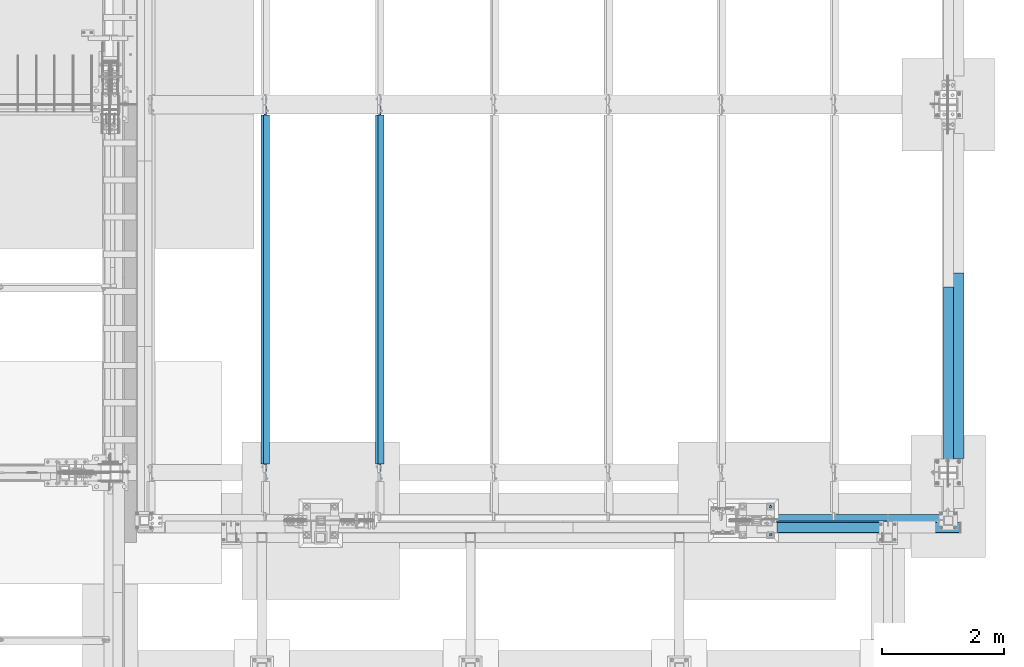
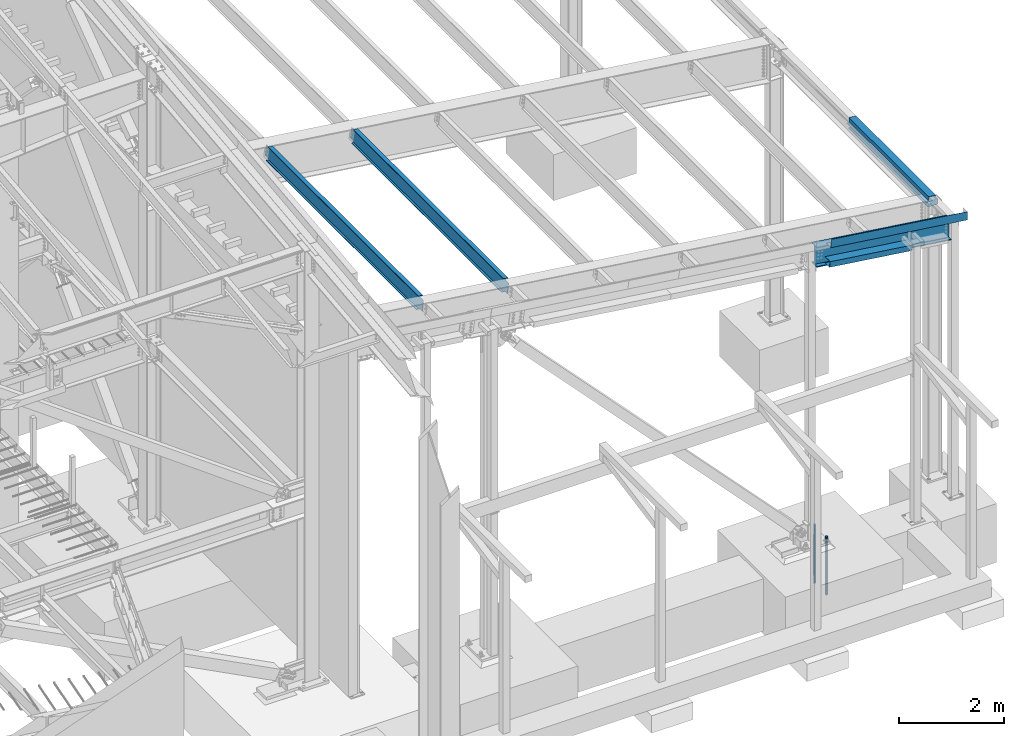
# One storey, part 746 of 1179: 9 beams, 5 elements without a shape of their own.
"""IFC2X3 building model written with IfcOpenShell, lengths in millimetres."""

from ifc_helpers import new_model, si_unit, frame, origin_with_axes, place, context, subcontext, project, spatial, faceted_brep, material, type_object, element, aggregate, save


model = new_model("IFC2X3")

# Units and contexts
model_context = context("Model", 3, precision=1e-05, world=origin_with_axes())
body_context = subcontext(model_context, "Body", "Model", "MODEL_VIEW")
ifc_project = project(units=[si_unit("LENGTHUNIT", "METRE", prefix="MILLI"), si_unit("AREAUNIT", "SQUARE_METRE"), si_unit("VOLUMEUNIT", "CUBIC_METRE"), si_unit("MASSUNIT", "GRAM", prefix="KILO"), si_unit("TIMEUNIT", "SECOND"), si_unit("PLANEANGLEUNIT", "RADIAN"), si_unit("SOLIDANGLEUNIT", "STERADIAN"), si_unit("THERMODYNAMICTEMPERATUREUNIT", "DEGREE_CELSIUS"), si_unit("LUMINOUSINTENSITYUNIT", "LUMEN")], contexts=[model_context])

# Site, building, storey
site_placement = place(None, origin_with_axes())
site = spatial("IfcSite", under=ifc_project, at=site_placement, CompositionType="ELEMENT")
building_placement = place(site_placement, origin_with_axes())
building = spatial("IfcBuilding", under=site, at=building_placement, Name="Undefined", CompositionType="ELEMENT")
storey_placement = place(building_placement, origin_with_axes())
storey = spatial("IfcBuildingStorey", under=building, at=storey_placement, Name="Undefined", CompositionType="ELEMENT", Elevation=0.0)

# Assembly, beams
assembly_1_placement = place(storey_placement, origin_with_axes())
assembly_1 = element("IfcElementAssembly", 1, at=assembly_1_placement, inside=storey, Name="BEAM", AssemblyPlace="NOTDEFINED", PredefinedType="RIGID_FRAME")
ifc_material_1 = material(Name="STEEL/A36")
beam_type_1 = type_object("IfcBeamType", PredefinedType="NOTDEFINED")
beam_1_placement = place(assembly_1_placement, frame((37996.8124994167, 6962.77499999974, 6096.00000000004), z_axis=(0.0, -1.0, 0.0), x_axis=(0.0, 0.0, 1.0)))
beam_1 = element("IfcBeam", 2, at=beam_1_placement, type_object=beam_type_1, material=ifc_material_1, Name="BENT_PLATE", context=body_context, shape_type="Brep", body=[
    faceted_brep([(-2.91038304567337e-11, -4.76250000000073, -1524.0), (-2.91038304567337e-11, -4.76250000000073, 1524.0), (2.91038304567337e-11, 4.76250000000073, 1524.0), (2.91038304567337e-11, 4.76250000000073, -1524.0), (92.8848876952779, 4.76250000074651, 1524.0), (92.8848876952779, 4.76250000074651, -1524.0), (81.9873102930469, -4.76249999933498, -1524.0), (81.9873102930469, -4.76249999933498, 1524.0), (70.5918350219381, -160.337506103519, 1524.0), (70.5918350219381, -160.337506103519, -1524.0), (62.266532833075, -150.812506103524, -1524.0), (62.266532833075, -150.812506103524, 1524.0), (-7.6397554948926e-11, -160.337506103519, 1524.0), (-7.6397554948926e-11, -160.337506103519, -1524.0), (8.54161044117063e-08, -150.812499999749, 1524.0), (8.54161044117063e-08, -150.812499999749, -1524.0)], [[[0, 1, 2, 3]], [[3, 2, 4, 5]], [[1, 0, 6, 7]], [[5, 4, 8, 9]], [[7, 6, 10, 11]], [[9, 8, 12, 13]], [[8, 4, 2, 1, 7, 11, 14, 12]], [[11, 10, 15, 14]], [[10, 6, 0, 3, 5, 9, 13, 15]], [[14, 15, 13, 12]]]),
])
beam_type_2 = type_object("IfcBeamType", PredefinedType="NOTDEFINED")
beam_2_placement = place(assembly_1_placement, frame((38112.7, 7189.78750000015, 5765.8), z_axis=(0.0, 1.0, 0.0), x_axis=(1.0, 0.0, 0.0)))
beam_2 = element("IfcBeam", 3, at=beam_2_placement, type_object=beam_type_2, material=ifc_material_1, Name="BENT_PLATE", context=body_context, shape_type="Brep", body=[
    faceted_brep([(0.0, -3.17499999999927, -1524.0), (6.00266503170133e-10, -3.17499999922438, 1524.00000000052), (6.00266503170133e-10, 3.17500000077416, 1524.00000000052), (0.0, 3.17499999999927, -1524.0), (215.900000000009, 3.17500000000018, 1524.0), (215.900000000009, 3.17500000000018, -1524.0), (209.550000000003, -3.17500000000018, -1524.0), (209.550000000003, -3.17500000000018, 1524.0), (215.900000000009, -123.825, 1524.0), (215.900000000009, -123.825, -1524.0), (209.550000000003, -117.474999999999, -1524.0), (209.550000000003, -117.474999999999, 1524.0), (-34.1312499999985, -123.825, 1524.0), (-34.1312499999985, -123.825, -1524.0), (-34.1312499999985, -117.474999999999, 1524.0), (-34.1312499999985, -117.474999999999, -1524.0)], [[[0, 1, 2, 3]], [[3, 2, 4, 5]], [[1, 0, 6, 7]], [[5, 4, 8, 9]], [[7, 6, 10, 11]], [[9, 8, 12, 13]], [[8, 4, 2, 1, 7, 11, 14, 12]], [[11, 10, 15, 14]], [[10, 6, 0, 3, 5, 9, 13, 15]], [[14, 15, 13, 12]]]),
])
aggregate(assembly_1, [beam_2, beam_1])

assembly_2_placement = place(storey_placement, origin_with_axes())
assembly_2 = element("IfcElementAssembly", 4, at=assembly_2_placement, inside=storey, Name="BEAM", AssemblyPlace="NOTDEFINED", PredefinedType="RIGID_FRAME")
beam_type_3 = type_object("IfcBeamType", PredefinedType="NOTDEFINED")
beam_3_placement = place(assembly_2_placement, frame((36794.3086923332, 4448.17500003039, 6542.84180397988), z_axis=(0.99100656965293, 0.0, -0.133813223953134), x_axis=(-0.133813222971046, 0.0, -0.991006569785539)))
beam_3 = element("IfcBeam", 5, at=beam_3_placement, type_object=beam_type_3, material=ifc_material_1, Name="BENT_PLATE", context=body_context, shape_type="Brep", body=[
    faceted_brep([(190.499999993961, -3.17500000000018, -1524.00000000063), (0.0, -3.17499999999927, -1524.0), (0.0, 3.17499999999927, -1524.0), (184.149999993959, 3.17500000000018, -1524.00000000062), (184.149999994715, 166.687499981327, -1524.00000000071), (190.499999994716, 166.687499981327, -1524.00000000072), (190.499999997646, -3.17500000000018, 1522.67681470571), (1.05865183286369e-09, -3.17500000000018, 1496.95405973812), (1.05865183286369e-09, 3.17500000000018, 1496.95405973813), (184.149999997644, 3.17500000000018, 1521.8193895401), (184.149999996893, 166.687499982885, 1521.81938954), (190.499999996895, 166.687499982886, 1522.67681470561)], [[[0, 1, 2, 3, 4, 5]], [[1, 0, 6, 7]], [[2, 1, 7, 8]], [[3, 2, 8, 9]], [[4, 3, 9, 10]], [[5, 4, 10, 11]], [[0, 5, 11, 6]], [[10, 9, 8, 7, 6, 11]]]),
])
beam_type_4 = type_object("IfcBeamType", PredefinedType="NOTDEFINED")
beam_4_placement = place(assembly_2_placement, frame((36156.5099994296, 4642.64374999811, 6109.94447129983), z_axis=(-0.99100656978554, 0.0, 0.133813222971043), x_axis=(0.0, -1.0, 0.0)))
beam_4 = element("IfcBeam", 6, at=beam_4_placement, type_object=beam_type_4, material=ifc_material_1, Name="BENT_PLATE", context=body_context, shape_type="Brep", body=[
    faceted_brep([(-2.72848410531878e-11, -3.17500000025393, -914.400000000191), (-2.72848410531878e-11, -3.17499999974825, 914.400000000205), (2.72848410531878e-11, 3.17500000025393, 914.400000000191), (2.72848410531878e-11, 3.17499999974825, -914.400000000198), (197.643750000188, 3.17499999857864, 914.400000000198), (197.643750000961, 3.1749999980766, -914.400000000205), (191.293750000961, -3.17500000187283, -914.400000000191), (191.293750000189, -3.17500000137079, 914.400000000198), (197.643750000575, -123.825000005945, 914.400000000394), (197.643750000575, -123.825000007779, -914.400000000001), (191.293750000575, -117.475000009899, -914.400000000009), (191.293750000575, -117.475000008064, 914.400000000387), (27.7812499964821, -123.82500006292, 914.400000000445), (27.7812499959236, -123.825000064255, -914.399999999951), (27.7812499943611, -117.475000062917, 914.400000000438), (27.7812499938027, -117.475000064253, -914.399999999958)], [[[0, 1, 2, 3]], [[3, 2, 4, 5]], [[1, 0, 6, 7]], [[5, 4, 8, 9]], [[7, 6, 10, 11]], [[9, 8, 12, 13]], [[8, 4, 2, 1, 7, 11, 14, 12]], [[11, 10, 15, 14]], [[10, 6, 0, 3, 5, 9, 13, 15]], [[14, 15, 13, 12]]]),
])
ifc_material_2 = material(Name="STEEL/A992")
beam_type_5 = type_object("IfcBeamType", Name="W18X65", PredefinedType="NOTDEFINED")
beam_5_placement = place(assembly_2_placement, frame((34893.773011526, 4648.2, 6371.75747568205), z_axis=(0.133813223953133, 0.0, 0.991006569652931), x_axis=(0.99100656965293, 0.0, -0.133813223953134)))
beam_5 = element("IfcBeam", 7, at=beam_5_placement, type_object=beam_type_5, material=ifc_material_2, Name="BEAM", ObjectType="W18X65", context=body_context, shape_type="Brep", body=[
    faceted_brep([(150.155245776514, -96.8374999999996, -214.312500000113), (152.727521273322, -96.8374999999996, -233.362500000119), (3151.49674340121, -96.8374999999996, -233.362500000949), (3148.92446790441, -96.8374999999996, -214.312500000942), (150.155245776514, -5.55624999999964, -214.312500000113), (3148.92446790441, -5.55624999999964, -214.312500000942), (92.2790470984037, -5.55624999999964, 214.312500000047), (3091.0482692263, -5.55624999999964, 214.312499999221), (92.2790470984037, -96.8374999999996, 214.312500000047), (3091.0482692263, -96.8374999999996, 214.312499999221), (89.7067716015954, -96.8374999999996, 233.362500000056), (3088.47599372949, -96.8374999999996, 233.362499999228), (89.7067716015954, 96.8374999999996, 233.362500000056), (3088.47599372949, 96.8374999999996, 233.362499999228), (92.2790470984037, 96.8374999999996, 214.312500000047), (3091.0482692263, 96.8374999999996, 214.312499999221), (92.2790470984037, 5.55624999999964, 214.312500000047), (3091.0482692263, 5.55624999999964, 214.312499999221), (150.155245776514, 5.55624999999964, -214.312500000113), (3148.92446790441, 5.55624999999964, -214.312500000942), (150.155245776514, 96.8374999999996, -214.312500000113), (3148.92446790441, 96.8374999999996, -214.312500000942), (152.727521273322, 96.8374999999996, -233.362500000119), (3151.49674340121, 96.8374999999996, -233.362500000949)], [[[0, 1, 2, 3]], [[4, 0, 3, 5]], [[6, 4, 5, 7]], [[8, 6, 7, 9]], [[10, 8, 9, 11]], [[12, 10, 11, 13]], [[14, 12, 13, 15]], [[16, 14, 15, 17]], [[18, 16, 17, 19]], [[20, 18, 19, 21]], [[1, 0, 4, 6, 8, 10, 12, 14, 16, 18, 20, 22]], [[1, 22, 23, 2]], [[19, 17, 15, 13, 11, 9, 7, 5, 3, 2, 23, 21]], [[22, 20, 21, 23]]]),
])
aggregate(assembly_2, [beam_3, beam_4, beam_5])

# Assembly, beam
assembly_3_placement = place(storey_placement, origin_with_axes())
assembly_3 = element("IfcElementAssembly", 8, at=assembly_3_placement, inside=storey, Name="BEAM", AssemblyPlace="NOTDEFINED", PredefinedType="RIGID_FRAME")
beam_type_6 = type_object("IfcBeamType", Name="W12X22", PredefinedType="NOTDEFINED")
beam_6_placement = place(assembly_3_placement, frame((26852.3820076832, 5435.6, 7536.06050920309), z_axis=(0.133813223953133, 0.0, 0.991006569652931), x_axis=(0.0, 1.0, 0.0)))
beam_6 = element("IfcBeam", 9, at=beam_6_placement, type_object=beam_type_6, material=ifc_material_2, Name="BEAM", ObjectType="W12X22", context=body_context, shape_type="Brep", body=[
    faceted_brep([(5880.09999999999, -3.17499999983193, -144.462500000051), (5880.09999999999, -50.7999999998428, -144.462500000063), (5880.09999999999, -50.7999999998283, -155.575000000068), (5880.09999999999, 50.8000000001921, -155.575000000041), (5880.09999999999, 50.8000000001848, -144.462500000036), (5880.09999999999, 3.17500000017026, -144.462500000049), (5880.09999999999, 3.17500000016298, -136.52499982221), (5880.09999999999, -3.17499999983556, -136.524999822204), (5881.06672992258, 3.17500000015571, -131.66492030416), (5881.06672992258, -3.17499999984648, -131.664920304156), (5883.81974382306, 3.17500000015207, -127.544743836002), (5883.81974382306, -3.17499999985012, -127.544743835997), (5887.93992029121, 3.17500000014843, -124.791729935519), (5887.93992029121, -3.17499999985375, -124.791729935516), (5892.79999980926, 3.17500000014843, -123.825000012932), (5892.79999980926, -3.17499999985375, -123.825000012926), (6024.5625, -3.17499999985375, -123.825000012823), (6024.5625, 3.17500000014479, -123.825000012814), (144.4625, 3.17499999983193, 144.462500000049), (144.4625, 50.7999999998428, 144.462500000061), (5880.09999999999, 50.7999999998428, 144.462500000061), (5880.09999999999, 3.17499999983193, 144.462500000049), (146.049999999999, -3.1749999998392, -136.524999805057), (146.049999999999, 3.17500000015934, -136.52499980506), (146.049999999999, 3.17500000017026, -144.462500000049), (146.049999999999, 50.8000000001848, -144.462500000036), (146.049999999999, 50.8000000001921, -155.575000000041), (146.049999999999, -50.7999999998283, -155.575000000068), (146.049999999999, -50.7999999998428, -144.462500000063), (146.049999999999, -3.17499999983193, -144.462500000051), (145.083270077412, -3.17499999984284, -131.664920287005), (145.083270077412, 3.17500000015571, -131.664920287008), (142.330256176933, -3.17499999985012, -127.544743818849), (142.330256176933, 3.17500000015207, -127.544743818851), (138.21007970878, -3.17499999985375, -124.791729918366), (138.21007970878, 3.17500000014479, -124.791729918372), (133.350000190734, -3.17499999985375, -123.824999995779), (133.350000190734, 3.17500000014843, -123.824999995781), (19.0500000000002, -3.17499999985375, -123.824999995893), (19.0500000000002, 3.17500000014843, -123.824999995886), (19.0500000000002, -3.17500000013752, 117.475000004351), (19.0500000000002, 3.17499999986467, 117.475000004359), (131.762500190734, -3.17500000013752, 117.47500000447), (131.762500190734, 3.17499999986467, 117.475000004464), (136.62257970878, -3.17500000013752, 118.441729927057), (136.62257970878, 3.17499999986103, 118.441729927054), (140.742756176934, -3.17500000014115, 121.194743827538), (140.742756176934, 3.17499999986103, 121.194743827535), (143.495770077412, -3.17500000014479, 125.314920295696), (143.495770077412, 3.17499999985375, 125.314920295692), (144.4625, -3.17500000015571, 130.174999813746), (144.4625, 3.17499999984648, 130.174999813742), (144.4625, -50.8000000001921, 155.575000000039), (144.4625, 50.7999999998283, 155.575000000066), (144.4625, -3.17500000016662, 144.462500000047), (144.4625, -50.8000000001812, 144.462500000034), (5880.09999999999, -3.17500000016662, 144.462500000047), (5880.09999999999, -50.8000000001812, 144.462500000034), (5880.09999999999, -50.8000000001921, 155.575000000039), (5880.09999999999, 50.7999999998283, 155.575000000066), (5880.09999999999, -3.17500000015207, 130.17499979644), (5880.09999999999, 3.17499999985012, 130.174999796436), (5881.06672992258, -3.17500000014843, 125.314920278392), (5881.06672992258, 3.17499999985012, 125.314920278386), (5883.81974382306, -3.17500000014479, 121.194743810232), (5883.81974382306, 3.17499999985739, 121.194743810229), (5887.93992029121, -3.17500000013752, 118.441729909751), (5887.93992029121, 3.17499999986103, 118.441729909748), (5892.79999980926, -3.17500000013752, 117.474999987164), (5892.79999980926, 3.17499999986467, 117.474999987158), (6024.5625, -3.17500000013752, 117.474999987267), (6024.5625, 3.17499999986467, 117.474999987275)], [[[0, 1, 2, 3, 4, 5, 6, 7]], [[7, 6, 8, 9]], [[9, 8, 10, 11]], [[11, 10, 12, 13]], [[13, 12, 14, 15]], [[16, 15, 14, 17]], [[18, 19, 20, 21]], [[22, 23, 24, 25, 26, 27, 28, 29]], [[30, 31, 23, 22]], [[32, 33, 31, 30]], [[34, 35, 33, 32]], [[36, 37, 35, 34]], [[38, 39, 37, 36]], [[40, 41, 39, 38]], [[42, 43, 41, 40]], [[44, 45, 43, 42]], [[46, 47, 45, 44]], [[48, 49, 47, 46]], [[50, 51, 49, 48]], [[52, 53, 19, 18, 51, 50, 54, 55]], [[55, 54, 56, 57]], [[52, 55, 57, 58]], [[53, 52, 58, 59]], [[19, 53, 59, 20]], [[58, 57, 56, 60, 61, 21, 20, 59]], [[62, 63, 61, 60]], [[64, 65, 63, 62]], [[66, 67, 65, 64]], [[68, 69, 67, 66]], [[70, 71, 69, 68]], [[71, 70, 16, 17]], [[12, 10, 8, 6, 5, 24, 23, 31, 33, 35, 37, 39, 41, 43, 45, 47, 49, 51, 18, 21, 61, 63, 65, 67, 69, 71, 17, 14]], [[25, 24, 5, 4]], [[26, 25, 4, 3]], [[27, 26, 3, 2]], [[28, 27, 2, 1]], [[29, 28, 1, 0]], [[70, 68, 66, 64, 62, 60, 56, 54, 50, 48, 46, 44, 42, 40, 38, 36, 34, 32, 30, 22, 29, 0, 7, 9, 11, 13, 15, 16]]]),
])
aggregate(assembly_3, [beam_6])

assembly_4_placement = place(storey_placement, origin_with_axes())
assembly_4 = element("IfcElementAssembly", 10, at=assembly_4_placement, inside=storey, Name="BEAM", AssemblyPlace="NOTDEFINED", PredefinedType="RIGID_FRAME")
beam_7_placement = place(assembly_4_placement, frame((28731.9820076832, 5435.6, 7282.26266018511), z_axis=(0.133813223953133, 0.0, 0.991006569652931), x_axis=(0.0, 1.0, 0.0)))
beam_7 = element("IfcBeam", 11, at=beam_7_placement, type_object=beam_type_6, material=ifc_material_2, Name="BEAM", ObjectType="W12X22", context=body_context, shape_type="Brep", body=[
    faceted_brep([(5880.09999999999, -3.17499999983193, -144.462500000051), (5880.09999999999, -50.7999999998428, -144.462500000063), (5880.09999999999, -50.7999999998283, -155.575000000068), (5880.09999999999, 50.8000000001921, -155.575000000041), (5880.09999999999, 50.8000000001848, -144.462500000036), (5880.09999999999, 3.17500000017026, -144.462500000049), (5880.09999999999, 3.17500000016298, -136.52499982221), (5880.09999999999, -3.17499999983556, -136.524999822204), (5881.06672992258, 3.17500000015571, -131.66492030416), (5881.06672992258, -3.17499999984648, -131.664920304156), (5883.81974382306, 3.17500000015207, -127.544743836002), (5883.81974382306, -3.17499999985012, -127.544743835997), (5887.93992029121, 3.17500000014843, -124.791729935519), (5887.93992029121, -3.17499999985375, -124.791729935516), (5892.79999980926, 3.17500000014843, -123.825000012932), (5892.79999980926, -3.17499999985375, -123.825000012926), (6024.5625, -3.17499999985375, -123.825000012823), (6024.5625, 3.17500000014479, -123.825000012814), (144.4625, 3.17499999983193, 144.462500000049), (144.4625, 50.7999999998428, 144.462500000061), (5880.09999999999, 50.7999999998428, 144.462500000061), (5880.09999999999, 3.17499999983193, 144.462500000049), (146.049999999999, -3.1749999998392, -136.524999805057), (146.049999999999, 3.17500000015934, -136.52499980506), (146.049999999999, 3.17500000017026, -144.462500000049), (146.049999999999, 50.8000000001848, -144.462500000036), (146.049999999999, 50.8000000001921, -155.575000000041), (146.049999999999, -50.7999999998283, -155.575000000068), (146.049999999999, -50.7999999998428, -144.462500000063), (146.049999999999, -3.17499999983193, -144.462500000051), (145.083270077412, -3.17499999984284, -131.664920287005), (145.083270077412, 3.17500000015571, -131.664920287008), (142.330256176933, -3.17499999985012, -127.544743818849), (142.330256176933, 3.17500000015207, -127.544743818851), (138.21007970878, -3.17499999985375, -124.791729918366), (138.21007970878, 3.17500000014479, -124.791729918372), (133.350000190734, -3.17499999985375, -123.824999995779), (133.350000190734, 3.17500000014843, -123.824999995781), (19.0500000000002, -3.17499999985375, -123.824999995893), (19.0500000000002, 3.17500000014843, -123.824999995886), (19.0500000000002, -3.17500000013752, 117.475000004351), (19.0500000000002, 3.17499999986467, 117.475000004359), (131.762500190734, -3.17500000013752, 117.47500000447), (131.762500190734, 3.17499999986467, 117.475000004464), (136.62257970878, -3.17500000013752, 118.441729927057), (136.62257970878, 3.17499999986103, 118.441729927054), (140.742756176934, -3.17500000014115, 121.194743827538), (140.742756176934, 3.17499999986103, 121.194743827535), (143.495770077412, -3.17500000014479, 125.314920295696), (143.495770077412, 3.17499999985375, 125.314920295692), (144.4625, -3.17500000015571, 130.174999813746), (144.4625, 3.17499999984648, 130.174999813742), (144.4625, -50.8000000001921, 155.575000000039), (144.4625, 50.7999999998283, 155.575000000066), (144.4625, -3.17500000016662, 144.462500000047), (144.4625, -50.8000000001812, 144.462500000034), (5880.09999999999, -3.17500000016662, 144.462500000047), (5880.09999999999, -50.8000000001812, 144.462500000034), (5880.09999999999, -50.8000000001921, 155.575000000039), (5880.09999999999, 50.7999999998283, 155.575000000066), (5880.09999999999, -3.17500000015207, 130.17499979644), (5880.09999999999, 3.17499999985012, 130.174999796436), (5881.06672992258, -3.17500000014843, 125.314920278392), (5881.06672992258, 3.17499999985012, 125.314920278386), (5883.81974382306, -3.17500000014479, 121.194743810232), (5883.81974382306, 3.17499999985739, 121.194743810229), (5887.93992029121, -3.17500000013752, 118.441729909751), (5887.93992029121, 3.17499999986103, 118.441729909748), (5892.79999980926, -3.17500000013752, 117.474999987164), (5892.79999980926, 3.17499999986467, 117.474999987158), (6024.5625, -3.17500000013752, 117.474999987267), (6024.5625, 3.17499999986467, 117.474999987275)], [[[0, 1, 2, 3, 4, 5, 6, 7]], [[7, 6, 8, 9]], [[9, 8, 10, 11]], [[11, 10, 12, 13]], [[13, 12, 14, 15]], [[16, 15, 14, 17]], [[18, 19, 20, 21]], [[22, 23, 24, 25, 26, 27, 28, 29]], [[30, 31, 23, 22]], [[32, 33, 31, 30]], [[34, 35, 33, 32]], [[36, 37, 35, 34]], [[38, 39, 37, 36]], [[40, 41, 39, 38]], [[42, 43, 41, 40]], [[44, 45, 43, 42]], [[46, 47, 45, 44]], [[48, 49, 47, 46]], [[50, 51, 49, 48]], [[52, 53, 19, 18, 51, 50, 54, 55]], [[55, 54, 56, 57]], [[52, 55, 57, 58]], [[53, 52, 58, 59]], [[19, 53, 59, 20]], [[58, 57, 56, 60, 61, 21, 20, 59]], [[62, 63, 61, 60]], [[64, 65, 63, 62]], [[66, 67, 65, 64]], [[68, 69, 67, 66]], [[70, 71, 69, 68]], [[71, 70, 16, 17]], [[12, 10, 8, 6, 5, 24, 23, 31, 33, 35, 37, 39, 41, 43, 45, 47, 49, 51, 18, 21, 61, 63, 65, 67, 69, 71, 17, 14]], [[25, 24, 5, 4]], [[26, 25, 4, 3]], [[27, 26, 3, 2]], [[28, 27, 2, 1]], [[29, 28, 1, 0]], [[70, 68, 66, 64, 62, 60, 56, 54, 50, 48, 46, 44, 42, 40, 38, 36, 34, 32, 30, 22, 29, 0, 7, 9, 11, 13, 15, 16]]]),
])
aggregate(assembly_4, [beam_7])

# Assembly, beams
assembly_5_placement = place(storey_placement, origin_with_axes())
assembly_5 = element("IfcElementAssembly", 12, at=assembly_5_placement, inside=storey, Name="TEMPLATE", AssemblyPlace="NOTDEFINED", PredefinedType="RIGID_FRAME")
ifc_material_3 = material(Name="STEEL/F1554-GR.55")
beam_type_7 = type_object("IfcBeamType", PredefinedType="NOTDEFINED")
beam_8_placement = place(assembly_5_placement, frame((35153.6, 4876.8, -355.6), z_axis=(0.0, 1.0, 0.0), x_axis=(0.0, 0.0, -1.0)))
beam_8 = element("IfcBeam", 13, at=beam_8_placement, type_object=beam_type_7, material=ifc_material_3, Name="ANCHOR_ROD", context=body_context, shape_type="Brep", body=[
    faceted_brep([(-244.475, -21.2176223927163, 12.25), (-244.475, -12.25, 21.217622392719), (-244.475, 0.0, 24.5), (-244.475, 12.25, 21.217622392719), (-244.475, 21.2176223927163, 12.25), (-244.475, 24.5, 0.0), (-244.475, 21.2176223927163, -12.25), (-244.475, 12.25, -21.217622392719), (-244.475, 0.0, -24.5), (-244.475, -12.25, -21.217622392719), (-244.475, -21.2176223927163, -12.25), (-244.475, -24.5, 0.0), (0.0, 24.5, 0.0), (0.0, 21.2176223927163, -12.25), (0.0, 12.25, -21.217622392719), (0.0, 0.0, -24.5), (0.0, -12.25, -21.217622392719), (0.0, -21.2176223927163, -12.25), (0.0, -24.5, 0.0), (0.0, -21.2176223927163, 12.25), (0.0, -12.25, 21.217622392719), (0.0, 0.0, 24.5), (0.0, 12.25, 21.217622392719), (0.0, 21.2176223927163, 12.25), (0.0, -23.466540125788, 9.72015918207308), (0.0, -17.9605122421417, 17.9605122421381), (0.0, -9.72015918207035, 23.4665401257871), (0.0, 0.0, 25.3999999999996), (0.0, 9.72015918207035, 23.4665401257871), (0.0, 17.9605122421417, 17.9605122421381), (0.0, 23.466540125788, 9.72015918207308), (0.0, 25.4000000000015, 0.0), (0.0, 23.466540125788, -9.72015918207308), (0.0, 17.9605122421417, -17.9605122421381), (0.0, 9.72015918207035, -23.4665401257871), (0.0, 0.0, -25.3999999999996), (0.0, -9.72015918207035, -23.4665401257871), (0.0, -17.9605122421417, -17.9605122421381), (0.0, -23.466540125788, -9.72015918207308), (0.0, -25.4000000000015, 0.0), (946.149999999999, -25.4000000000015, 0.0), (946.149999999999, -23.466540125788, 9.72015918207308), (946.149999999999, -17.9605122421417, 17.9605122421381), (946.149999999999, -9.72015918207035, 23.4665401257871), (946.149999999999, 0.0, 25.3999999999996), (946.149999999999, 9.72015918207035, 23.4665401257871), (946.149999999999, 17.9605122421417, 17.9605122421381), (946.149999999999, 23.466540125788, 9.72015918207308), (946.149999999999, 25.4000000000015, 0.0), (946.149999999999, 23.466540125788, -9.72015918207308), (946.149999999999, 17.9605122421417, -17.9605122421381), (946.149999999999, 9.72015918207035, -23.4665401257871), (946.149999999999, 0.0, -25.3999999999996), (946.149999999999, -9.72015918207035, -23.4665401257871), (946.149999999999, -17.9605122421417, -17.9605122421381), (946.149999999999, -23.466540125788, -9.72015918207308), (946.149999999999, -12.2499999999927, 21.217622392719), (946.149999999999, 7.27595761418343e-12, 24.5), (946.149999999999, 12.2500000000073, 21.217622392719), (946.149999999999, 21.2176223927236, 12.25), (946.149999999999, 24.5000000000073, 0.0), (946.149999999999, 21.2176223927236, -12.25), (946.149999999999, 12.2500000000073, -21.217622392719), (946.149999999999, 7.27595761418343e-12, -24.5), (946.149999999999, -12.2499999999927, -21.217622392719), (946.149999999999, -21.217622392709, -12.25), (946.149999999999, -24.4999999999927, 0.0), (946.149999999999, -21.217622392709, 12.25), (1117.6, -12.2499999999927, -21.217622392719), (1117.6, 7.27595761418343e-12, -24.5), (1117.6, 12.2500000000073, -21.217622392719), (1117.6, 21.2176223927236, -12.25), (1117.6, 24.5000000000073, 0.0), (1117.6, 21.2176223927236, 12.25), (1117.6, 12.2500000000073, 21.217622392719), (1117.6, 7.27595761418343e-12, 24.5), (1117.6, -12.2499999999927, 21.217622392719), (1117.6, -21.217622392709, 12.25), (1117.6, -24.4999999999927, 0.0), (1117.6, -21.217622392709, -12.25)], [[[0, 1, 2, 3, 4, 5, 6, 7, 8, 9, 10, 11]], [[6, 5, 12, 13]], [[7, 6, 13, 14]], [[8, 7, 14, 15]], [[9, 8, 15, 16]], [[10, 9, 16, 17]], [[11, 10, 17, 18]], [[0, 11, 18, 19]], [[1, 0, 19, 20]], [[2, 1, 20, 21]], [[3, 2, 21, 22]], [[4, 3, 22, 23]], [[5, 4, 23, 12]], [[24, 25, 26, 27, 28, 29, 30, 31, 32, 33, 34, 35, 36, 37, 38, 39], [22, 21, 20, 19, 18, 17, 16, 15, 14, 13, 12, 23]], [[24, 39, 40, 41]], [[25, 24, 41, 42]], [[26, 25, 42, 43]], [[27, 26, 43, 44]], [[28, 27, 44, 45]], [[29, 28, 45, 46]], [[30, 29, 46, 47]], [[31, 30, 47, 48]], [[32, 31, 48, 49]], [[33, 32, 49, 50]], [[34, 33, 50, 51]], [[35, 34, 51, 52]], [[36, 35, 52, 53]], [[37, 36, 53, 54]], [[38, 37, 54, 55]], [[39, 38, 55, 40]], [[54, 53, 52, 51, 50, 49, 48, 47, 46, 45, 44, 43, 42, 41, 40, 55], [56, 57, 58, 59, 60, 61, 62, 63, 64, 65, 66, 67]], [[68, 69, 70, 71, 72, 73, 74, 75, 76, 77, 78, 79]], [[76, 75, 57, 56]], [[77, 76, 56, 67]], [[78, 77, 67, 66]], [[79, 78, 66, 65]], [[68, 79, 65, 64]], [[69, 68, 64, 63]], [[70, 69, 63, 62]], [[71, 70, 62, 61]], [[72, 71, 61, 60]], [[73, 72, 60, 59]], [[74, 73, 59, 58]], [[75, 74, 58, 57]]]),
])
beam_9_placement = place(assembly_5_placement, frame((35153.6, 4419.6, -355.6), z_axis=(0.0, 1.0, 0.0), x_axis=(0.0, 0.0, -1.0)))
beam_9 = element("IfcBeam", 14, at=beam_9_placement, type_object=beam_type_7, material=ifc_material_3, Name="ANCHOR_ROD", context=body_context, shape_type="Brep", body=[
    faceted_brep([(-244.475, -21.2176223927163, 12.25), (-244.475, -12.25, 21.217622392719), (-244.475, 0.0, 24.5), (-244.475, 12.25, 21.217622392719), (-244.475, 21.2176223927163, 12.25), (-244.475, 24.5, 0.0), (-244.475, 21.2176223927163, -12.25), (-244.475, 12.25, -21.217622392719), (-244.475, 0.0, -24.5), (-244.475, -12.25, -21.217622392719), (-244.475, -21.2176223927163, -12.25), (-244.475, -24.5, 0.0), (0.0, 24.5, 0.0), (0.0, 21.2176223927163, -12.25), (0.0, 12.25, -21.217622392719), (0.0, 0.0, -24.5), (0.0, -12.25, -21.217622392719), (0.0, -21.2176223927163, -12.25), (0.0, -24.5, 0.0), (0.0, -21.2176223927163, 12.25), (0.0, -12.25, 21.217622392719), (0.0, 0.0, 24.5), (0.0, 12.25, 21.217622392719), (0.0, 21.2176223927163, 12.25), (0.0, -23.466540125788, 9.72015918207308), (0.0, -17.9605122421417, 17.9605122421381), (0.0, -9.72015918207035, 23.4665401257871), (0.0, 0.0, 25.3999999999996), (0.0, 9.72015918207035, 23.4665401257871), (0.0, 17.9605122421417, 17.9605122421381), (0.0, 23.466540125788, 9.72015918207308), (0.0, 25.4000000000015, 0.0), (0.0, 23.466540125788, -9.72015918207308), (0.0, 17.9605122421417, -17.9605122421381), (0.0, 9.72015918207035, -23.4665401257871), (0.0, 0.0, -25.3999999999996), (0.0, -9.72015918207035, -23.4665401257871), (0.0, -17.9605122421417, -17.9605122421381), (0.0, -23.466540125788, -9.72015918207308), (0.0, -25.4000000000015, 0.0), (946.149999999999, -25.4000000000015, 0.0), (946.149999999999, -23.466540125788, 9.72015918207308), (946.149999999999, -17.9605122421417, 17.9605122421381), (946.149999999999, -9.72015918207035, 23.4665401257871), (946.149999999999, 0.0, 25.3999999999996), (946.149999999999, 9.72015918207035, 23.4665401257871), (946.149999999999, 17.9605122421417, 17.9605122421381), (946.149999999999, 23.466540125788, 9.72015918207308), (946.149999999999, 25.4000000000015, 0.0), (946.149999999999, 23.466540125788, -9.72015918207308), (946.149999999999, 17.9605122421417, -17.9605122421381), (946.149999999999, 9.72015918207035, -23.4665401257871), (946.149999999999, 0.0, -25.3999999999996), (946.149999999999, -9.72015918207035, -23.4665401257871), (946.149999999999, -17.9605122421417, -17.9605122421381), (946.149999999999, -23.466540125788, -9.72015918207308), (946.149999999999, -12.2499999999927, 21.217622392719), (946.149999999999, 7.27595761418343e-12, 24.5), (946.149999999999, 12.2500000000073, 21.217622392719), (946.149999999999, 21.2176223927236, 12.25), (946.149999999999, 24.5000000000073, 0.0), (946.149999999999, 21.2176223927236, -12.25), (946.149999999999, 12.2500000000073, -21.217622392719), (946.149999999999, 7.27595761418343e-12, -24.5), (946.149999999999, -12.2499999999927, -21.217622392719), (946.149999999999, -21.217622392709, -12.25), (946.149999999999, -24.4999999999927, 0.0), (946.149999999999, -21.217622392709, 12.25), (1117.6, -12.2499999999927, -21.217622392719), (1117.6, 7.27595761418343e-12, -24.5), (1117.6, 12.2500000000073, -21.217622392719), (1117.6, 21.2176223927236, -12.25), (1117.6, 24.5000000000073, 0.0), (1117.6, 21.2176223927236, 12.25), (1117.6, 12.2500000000073, 21.217622392719), (1117.6, 7.27595761418343e-12, 24.5), (1117.6, -12.2499999999927, 21.217622392719), (1117.6, -21.217622392709, 12.25), (1117.6, -24.4999999999927, 0.0), (1117.6, -21.217622392709, -12.25)], [[[0, 1, 2, 3, 4, 5, 6, 7, 8, 9, 10, 11]], [[6, 5, 12, 13]], [[7, 6, 13, 14]], [[8, 7, 14, 15]], [[9, 8, 15, 16]], [[10, 9, 16, 17]], [[11, 10, 17, 18]], [[0, 11, 18, 19]], [[1, 0, 19, 20]], [[2, 1, 20, 21]], [[3, 2, 21, 22]], [[4, 3, 22, 23]], [[5, 4, 23, 12]], [[24, 25, 26, 27, 28, 29, 30, 31, 32, 33, 34, 35, 36, 37, 38, 39], [22, 21, 20, 19, 18, 17, 16, 15, 14, 13, 12, 23]], [[24, 39, 40, 41]], [[25, 24, 41, 42]], [[26, 25, 42, 43]], [[27, 26, 43, 44]], [[28, 27, 44, 45]], [[29, 28, 45, 46]], [[30, 29, 46, 47]], [[31, 30, 47, 48]], [[32, 31, 48, 49]], [[33, 32, 49, 50]], [[34, 33, 50, 51]], [[35, 34, 51, 52]], [[36, 35, 52, 53]], [[37, 36, 53, 54]], [[38, 37, 54, 55]], [[39, 38, 55, 40]], [[54, 53, 52, 51, 50, 49, 48, 47, 46, 45, 44, 43, 42, 41, 40, 55], [56, 57, 58, 59, 60, 61, 62, 63, 64, 65, 66, 67]], [[68, 69, 70, 71, 72, 73, 74, 75, 76, 77, 78, 79]], [[76, 75, 57, 56]], [[77, 76, 56, 67]], [[78, 77, 67, 66]], [[79, 78, 66, 65]], [[68, 79, 65, 64]], [[69, 68, 64, 63]], [[70, 69, 63, 62]], [[71, 70, 62, 61]], [[72, 71, 61, 60]], [[73, 72, 60, 59]], [[74, 73, 59, 58]], [[75, 74, 58, 57]]]),
])
aggregate(assembly_5, [beam_8, beam_9])

save(model, "model.ifc")
